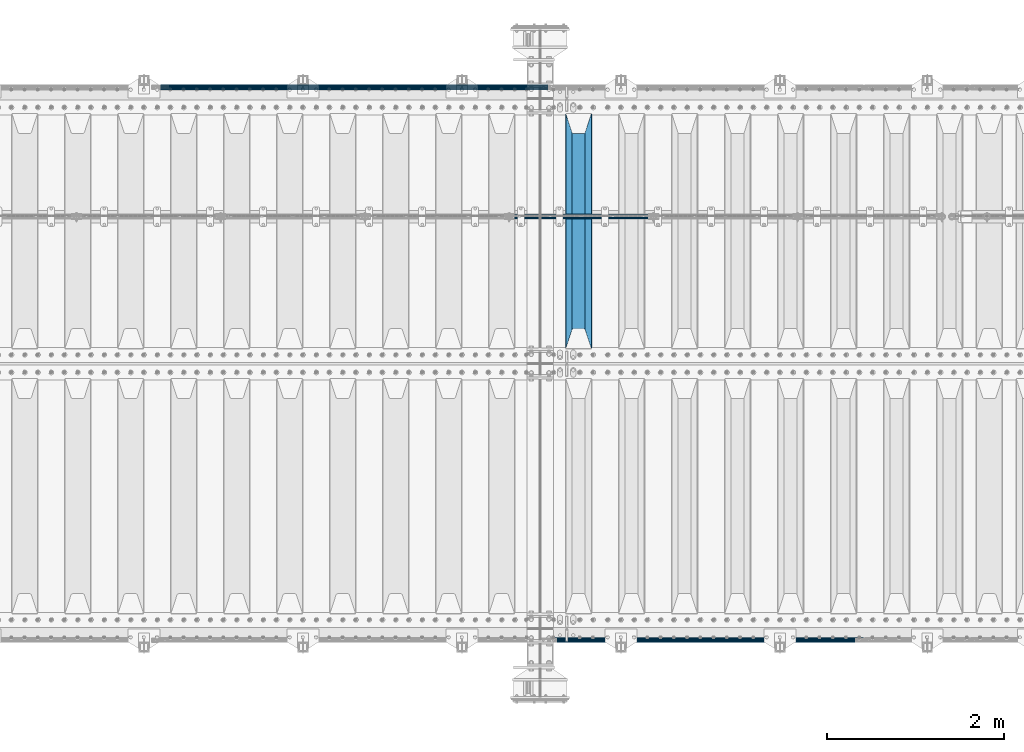
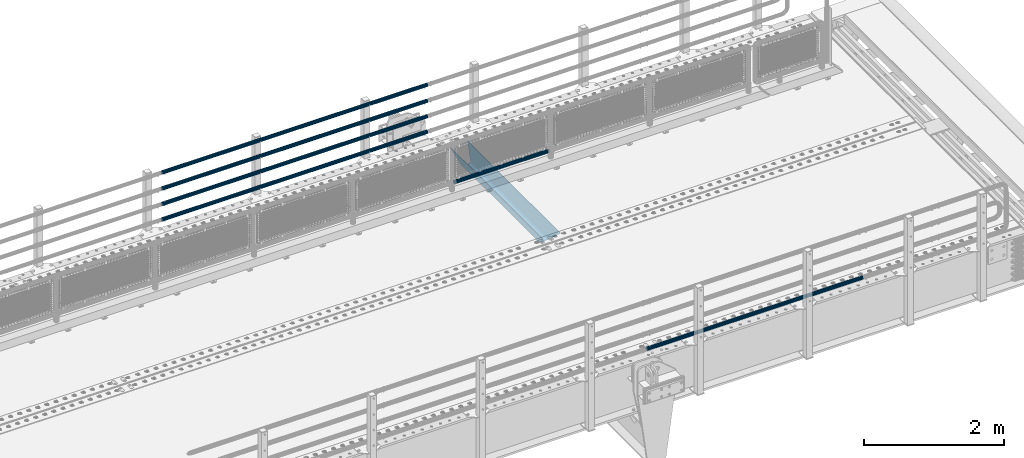
# One storey, part 127 of 242: 7 beams.
"""IFC2X3 building model written with IfcOpenShell, lengths in millimetres."""

from ifc_helpers import new_model, si_unit, frame, origin_with_axes, place, context, subcontext, project, spatial, faceted_brep, material, type_object, element, save


model = new_model("IFC2X3")

# Units and contexts
model_context = context("Model", 3, precision=1e-05, world=origin_with_axes())
body_context = subcontext(model_context, "Body", "Model", "MODEL_VIEW")
ifc_project = project(units=[si_unit("LENGTHUNIT", "METRE", prefix="MILLI"), si_unit("AREAUNIT", "SQUARE_METRE"), si_unit("VOLUMEUNIT", "CUBIC_METRE"), si_unit("MASSUNIT", "GRAM", prefix="KILO"), si_unit("TIMEUNIT", "SECOND"), si_unit("PLANEANGLEUNIT", "RADIAN"), si_unit("SOLIDANGLEUNIT", "STERADIAN"), si_unit("THERMODYNAMICTEMPERATUREUNIT", "DEGREE_CELSIUS"), si_unit("LUMINOUSINTENSITYUNIT", "LUMEN")], contexts=[model_context])

# Site, building, storey
site_placement = place(None, origin_with_axes())
site = spatial("IfcSite", under=ifc_project, at=site_placement, CompositionType="ELEMENT")
building_placement = place(site_placement, origin_with_axes())
building = spatial("IfcBuilding", under=site, at=building_placement, Name="Standard", CompositionType="ELEMENT")
storey_placement = place(building_placement, origin_with_axes())
storey = spatial("IfcBuildingStorey", under=building, at=storey_placement, Name="Undefined", CompositionType="ELEMENT", Elevation=0.0)

# Beams
ifc_material_1 = material()
beam_type_1 = type_object("IfcBeamType", PredefinedType="NOTDEFINED")
beam_1_placement = place(storey_placement, frame((-28730.15, -19335.5, 298.170000000001), z_axis=(0.0, 0.0, 1.0), x_axis=(1.0, 0.0, 0.0)))
element("IfcBeam", 1, at=beam_1_placement, inside=storey, type_object=beam_type_1, material=ifc_material_1, context=body_context, shape_type="Brep", body=[
    faceted_brep([(0.0, -25.3499999999985, 0.0), (0.0, -23.4203461491597, 9.70102501045403), (1563.0, -23.4203461491597, 9.70102501045506), (1563.0, -25.3499999999985, 0.0), (0.0, -17.9251569030785, 17.9251569030785), (1563.0, -17.9251569030785, 17.925156903079), (0.0, -9.70102501045403, 23.4203461491597), (1563.0, -9.70102501045403, 23.4203461491611), (0.0, 0.0, 25.3499999999985), (1563.0, 0.0, 25.35), (0.0, 9.70102501045403, 23.4203461491597), (1563.0, 9.70102501045403, 23.4203461491611), (0.0, 17.9251569030785, 17.9251569030785), (1563.0, 17.9251569030785, 17.925156903079), (0.0, 23.4203461491597, 9.70102501045403), (1563.0, 23.4203461491597, 9.70102501045506), (0.0, 25.3499999999985, 0.0), (1563.0, 25.3499999999985, 0.0), (0.0, 23.4203461491597, -9.70102501045403), (1563.0, 23.4203461491597, -9.70102501045506), (0.0, 17.9251569030785, -17.9251569030785), (1563.0, 17.9251569030785, -17.925156903079), (0.0, 9.70102501045403, -23.4203461491597), (1563.0, 9.70102501045403, -23.4203461491611), (0.0, 0.0, -25.3499999999985), (1563.0, 0.0, -25.35), (0.0, -9.70102501045403, -23.4203461491597), (1563.0, -9.70102501045403, -23.4203461491611), (0.0, -17.9251569030785, -17.9251569030785), (1563.0, -17.9251569030785, -17.925156903079), (0.0, -23.4203461491597, -9.70102501045403), (1563.0, -23.4203461491597, -9.70102501045506), (0.0, -30.1500000000015, 0.0), (0.0, -27.8549679052157, -11.5379054858058), (1563.0, -27.8549679052157, -11.5379054858075), (1563.0, -30.1500000000015, 0.0), (0.0, -21.3192694527752, -21.3192694527752), (1563.0, -21.3192694527752, -21.3192694527744), (0.0, -11.5379054858058, -27.8549679052157), (1563.0, -11.5379054858058, -27.8549679052153), (0.0, 0.0, -30.1500000000015), (1563.0, 0.0, -30.15), (0.0, 11.5379054858058, -27.8549679052157), (1563.0, 11.5379054858058, -27.8549679052153), (0.0, 21.3192694527752, -21.3192694527752), (1563.0, 21.3192694527752, -21.3192694527744), (0.0, 27.8549679052157, -11.5379054858058), (1563.0, 27.8549679052157, -11.5379054858074), (0.0, 30.1500000000015, 0.0), (1563.0, 30.1500000000015, 0.0), (0.0, 27.8549679052157, 11.5379054858058), (1563.0, 27.8549679052157, 11.5379054858074), (0.0, 21.3192694527752, 21.3192694527752), (1563.0, 21.3192694527752, 21.3192694527744), (0.0, 11.5379054858058, 27.8549679052157), (1563.0, 11.5379054858058, 27.8549679052153), (0.0, 0.0, 30.1500000000015), (1563.0, 0.0, 30.15), (0.0, -11.5379054858058, 27.8549679052157), (1563.0, -11.5379054858058, 27.8549679052153), (0.0, -21.3192694527752, 21.3192694527752), (1563.0, -21.3192694527752, 21.3192694527744), (0.0, -27.8549679052157, 11.5379054858058), (1563.0, -27.8549679052157, 11.5379054858074)], [[[0, 1, 2, 3]], [[1, 4, 5, 2]], [[4, 6, 7, 5]], [[6, 8, 9, 7]], [[8, 10, 11, 9]], [[10, 12, 13, 11]], [[12, 14, 15, 13]], [[14, 16, 17, 15]], [[16, 18, 19, 17]], [[18, 20, 21, 19]], [[20, 22, 23, 21]], [[22, 24, 25, 23]], [[24, 26, 27, 25]], [[26, 28, 29, 27]], [[28, 30, 31, 29]], [[30, 0, 3, 31]], [[32, 33, 34, 35]], [[33, 36, 37, 34]], [[36, 38, 39, 37]], [[38, 40, 41, 39]], [[40, 42, 43, 41]], [[42, 44, 45, 43]], [[44, 46, 47, 45]], [[46, 48, 49, 47]], [[48, 50, 51, 49]], [[50, 52, 53, 51]], [[52, 54, 55, 53]], [[54, 56, 57, 55]], [[56, 58, 59, 57]], [[58, 60, 61, 59]], [[60, 62, 63, 61]], [[62, 32, 35, 63]], [[37, 39, 41, 43, 45, 47, 49, 51, 53, 55, 57, 59, 61, 63, 35, 34], [5, 7, 9, 11, 13, 15, 17, 19, 21, 23, 25, 27, 29, 31, 3, 2]], [[62, 60, 58, 56, 54, 52, 50, 48, 46, 44, 42, 40, 38, 36, 33, 32], [30, 28, 26, 24, 22, 20, 18, 16, 14, 12, 10, 8, 6, 4, 1, 0]]]),
])
beam_type_2 = type_object("IfcBeamType", PredefinedType="NOTDEFINED")
beam_2_placement = place(storey_placement, frame((-28328.0000000001, -17870.1499999998, 149.849999999726), z_axis=(0.0, 0.0, -1.0), x_axis=(-1.0, 0.0, 0.0)))
element("IfcBeam", 2, at=beam_2_placement, inside=storey, type_object=beam_type_2, material=ifc_material_1, context=body_context, shape_type="Brep", body=[
    faceted_brep([(0.0, -26.5499999999993, 0.0), (0.0, -24.5290015881765, 10.1602451292931), (4384.0, -24.5290015881765, 10.1602451292931), (4384.0, -26.5499999999993, 0.0), (0.0, -18.7736850405017, 18.7736850405028), (4384.0, -18.7736850405017, 18.7736850405028), (0.0, -10.1602451292929, 24.5290015881747), (4384.0, -10.1602451292929, 24.5290015881747), (0.0, 0.0, 26.55), (4384.0, 0.0, 26.55), (0.0, 10.1602451292929, 24.5290015881747), (4384.0, 10.1602451292929, 24.5290015881747), (0.0, 18.7736850405017, 18.7736850405028), (4384.0, 18.7736850405017, 18.7736850405028), (0.0, 24.5290015881765, 10.1602451292931), (4384.0, 24.5290015881765, 10.1602451292931), (0.0, 26.5499999999993, 0.0), (4384.0, 26.5499999999993, 0.0), (0.0, 24.5290015881765, -10.1602451292931), (4384.0, 24.5290015881765, -10.1602451292931), (0.0, 18.7736850405017, -18.7736850405028), (4384.0, 18.7736850405017, -18.7736850405028), (0.0, 10.1602451292929, -24.5290015881747), (4384.0, 10.1602451292929, -24.5290015881747), (0.0, 0.0, -26.55), (4384.0, 0.0, -26.55), (0.0, -10.1602451292929, -24.5290015881747), (4384.0, -10.1602451292929, -24.5290015881747), (0.0, -18.7736850405017, -18.7736850405028), (4384.0, -18.7736850405017, -18.7736850405028), (0.0, -24.5290015881765, -10.1602451292931), (4384.0, -24.5290015881765, -10.1602451292931), (0.0, -30.1500000000015, 0.0), (0.0, -27.8549679052157, -11.5379054858058), (4384.0, -27.8549679052157, -11.5379054858075), (4384.0, -30.1500000000015, 0.0), (0.0, -21.3192694527752, -21.3192694527752), (4384.0, -21.3192694527752, -21.3192694527744), (0.0, -11.5379054858058, -27.8549679052157), (4384.0, -11.5379054858058, -27.8549679052153), (0.0, 0.0, -30.1500000000015), (4384.0, 0.0, -30.15), (0.0, 11.5379054858058, -27.8549679052157), (4384.0, 11.5379054858058, -27.8549679052153), (0.0, 21.3192694527752, -21.3192694527752), (4384.0, 21.3192694527752, -21.3192694527744), (0.0, 27.8549679052157, -11.5379054858058), (4384.0, 27.8549679052157, -11.5379054858074), (0.0, 30.1500000000015, 0.0), (4384.0, 30.1500000000015, 0.0), (0.0, 27.8549679052157, 11.5379054858058), (4384.0, 27.8549679052157, 11.5379054858075), (0.0, 21.3192694527752, 21.3192694527752), (4384.0, 21.3192694527752, 21.3192694527744), (0.0, 11.5379054858058, 27.8549679052157), (4384.0, 11.5379054858058, 27.8549679052153), (0.0, 0.0, 30.1500000000015), (4384.0, 0.0, 30.15), (0.0, -11.5379054858058, 27.8549679052157), (4384.0, -11.5379054858058, 27.8549679052153), (0.0, -21.3192694527752, 21.3192694527752), (4384.0, -21.3192694527752, 21.3192694527744), (0.0, -27.8549679052157, 11.5379054858058), (4384.0, -27.8549679052157, 11.5379054858075)], [[[0, 1, 2, 3]], [[1, 4, 5, 2]], [[4, 6, 7, 5]], [[6, 8, 9, 7]], [[8, 10, 11, 9]], [[10, 12, 13, 11]], [[12, 14, 15, 13]], [[14, 16, 17, 15]], [[16, 18, 19, 17]], [[18, 20, 21, 19]], [[20, 22, 23, 21]], [[22, 24, 25, 23]], [[24, 26, 27, 25]], [[26, 28, 29, 27]], [[28, 30, 31, 29]], [[30, 0, 3, 31]], [[32, 33, 34, 35]], [[33, 36, 37, 34]], [[36, 38, 39, 37]], [[38, 40, 41, 39]], [[40, 42, 43, 41]], [[42, 44, 45, 43]], [[44, 46, 47, 45]], [[46, 48, 49, 47]], [[48, 50, 51, 49]], [[50, 52, 53, 51]], [[52, 54, 55, 53]], [[54, 56, 57, 55]], [[56, 58, 59, 57]], [[58, 60, 61, 59]], [[60, 62, 63, 61]], [[62, 32, 35, 63]], [[37, 39, 41, 43, 45, 47, 49, 51, 53, 55, 57, 59, 61, 63, 35, 34], [5, 7, 9, 11, 13, 15, 17, 19, 21, 23, 25, 27, 29, 31, 3, 2]], [[62, 60, 58, 56, 54, 52, 50, 48, 46, 44, 42, 40, 38, 36, 33, 32], [30, 28, 26, 24, 22, 20, 18, 16, 14, 12, 10, 8, 6, 4, 1, 0]]]),
])
beam_3_placement = place(storey_placement, frame((-28328.0000000001, -17870.1499999998, 420.149999999729), z_axis=(0.0, 0.0, -1.0), x_axis=(-1.0, 0.0, 0.0)))
element("IfcBeam", 3, at=beam_3_placement, inside=storey, type_object=beam_type_2, material=ifc_material_1, context=body_context, shape_type="Brep", body=[
    faceted_brep([(0.0, -26.5499999999993, 0.0), (0.0, -24.5290015881765, 10.1602451292931), (4384.0, -24.5290015881765, 10.1602451292931), (4384.0, -26.5499999999993, 0.0), (0.0, -18.7736850405017, 18.7736850405028), (4384.0, -18.7736850405017, 18.7736850405028), (0.0, -10.1602451292929, 24.5290015881747), (4384.0, -10.1602451292929, 24.5290015881747), (0.0, 0.0, 26.55), (4384.0, 0.0, 26.55), (0.0, 10.1602451292929, 24.5290015881747), (4384.0, 10.1602451292929, 24.5290015881747), (0.0, 18.7736850405017, 18.7736850405028), (4384.0, 18.7736850405017, 18.7736850405028), (0.0, 24.5290015881765, 10.1602451292931), (4384.0, 24.5290015881765, 10.1602451292931), (0.0, 26.5499999999993, 0.0), (4384.0, 26.5499999999993, 0.0), (0.0, 24.5290015881765, -10.1602451292931), (4384.0, 24.5290015881765, -10.1602451292931), (0.0, 18.7736850405017, -18.7736850405028), (4384.0, 18.7736850405017, -18.7736850405028), (0.0, 10.1602451292929, -24.5290015881747), (4384.0, 10.1602451292929, -24.5290015881747), (0.0, 0.0, -26.55), (4384.0, 0.0, -26.55), (0.0, -10.1602451292929, -24.5290015881747), (4384.0, -10.1602451292929, -24.5290015881747), (0.0, -18.7736850405017, -18.7736850405028), (4384.0, -18.7736850405017, -18.7736850405028), (0.0, -24.5290015881765, -10.1602451292931), (4384.0, -24.5290015881765, -10.1602451292931), (0.0, -30.1500000000015, 0.0), (0.0, -27.8549679052157, -11.5379054858058), (4384.0, -27.8549679052157, -11.5379054858075), (4384.0, -30.1500000000015, 0.0), (0.0, -21.3192694527752, -21.3192694527752), (4384.0, -21.3192694527752, -21.3192694527744), (0.0, -11.5379054858058, -27.8549679052157), (4384.0, -11.5379054858058, -27.8549679052153), (0.0, 0.0, -30.1500000000015), (4384.0, 0.0, -30.15), (0.0, 11.5379054858058, -27.8549679052157), (4384.0, 11.5379054858058, -27.8549679052153), (0.0, 21.3192694527752, -21.3192694527752), (4384.0, 21.3192694527752, -21.3192694527744), (0.0, 27.8549679052157, -11.5379054858058), (4384.0, 27.8549679052157, -11.5379054858074), (0.0, 30.1500000000015, 0.0), (4384.0, 30.1500000000015, 0.0), (0.0, 27.8549679052157, 11.5379054858058), (4384.0, 27.8549679052157, 11.5379054858075), (0.0, 21.3192694527752, 21.3192694527752), (4384.0, 21.3192694527752, 21.3192694527744), (0.0, 11.5379054858058, 27.8549679052157), (4384.0, 11.5379054858058, 27.8549679052153), (0.0, 0.0, 30.1500000000015), (4384.0, 0.0, 30.15), (0.0, -11.5379054858058, 27.8549679052157), (4384.0, -11.5379054858058, 27.8549679052153), (0.0, -21.3192694527752, 21.3192694527752), (4384.0, -21.3192694527752, 21.3192694527744), (0.0, -27.8549679052157, 11.5379054858058), (4384.0, -27.8549679052157, 11.5379054858075)], [[[0, 1, 2, 3]], [[1, 4, 5, 2]], [[4, 6, 7, 5]], [[6, 8, 9, 7]], [[8, 10, 11, 9]], [[10, 12, 13, 11]], [[12, 14, 15, 13]], [[14, 16, 17, 15]], [[16, 18, 19, 17]], [[18, 20, 21, 19]], [[20, 22, 23, 21]], [[22, 24, 25, 23]], [[24, 26, 27, 25]], [[26, 28, 29, 27]], [[28, 30, 31, 29]], [[30, 0, 3, 31]], [[32, 33, 34, 35]], [[33, 36, 37, 34]], [[36, 38, 39, 37]], [[38, 40, 41, 39]], [[40, 42, 43, 41]], [[42, 44, 45, 43]], [[44, 46, 47, 45]], [[46, 48, 49, 47]], [[48, 50, 51, 49]], [[50, 52, 53, 51]], [[52, 54, 55, 53]], [[54, 56, 57, 55]], [[56, 58, 59, 57]], [[58, 60, 61, 59]], [[60, 62, 63, 61]], [[62, 32, 35, 63]], [[37, 39, 41, 43, 45, 47, 49, 51, 53, 55, 57, 59, 61, 63, 35, 34], [5, 7, 9, 11, 13, 15, 17, 19, 21, 23, 25, 27, 29, 31, 3, 2]], [[62, 60, 58, 56, 54, 52, 50, 48, 46, 44, 42, 40, 38, 36, 33, 32], [30, 28, 26, 24, 22, 20, 18, 16, 14, 12, 10, 8, 6, 4, 1, 0]]]),
])
beam_4_placement = place(storey_placement, frame((-28328.0000000001, -17870.1499999998, 969.849999999726), z_axis=(0.0, 0.0, -1.0), x_axis=(-1.0, 0.0, 0.0)))
element("IfcBeam", 4, at=beam_4_placement, inside=storey, type_object=beam_type_2, material=ifc_material_1, context=body_context, shape_type="Brep", body=[
    faceted_brep([(0.0, -26.5499999999993, 0.0), (0.0, -24.5290015881765, 10.1602451292931), (4384.0, -24.5290015881765, 10.1602451292931), (4384.0, -26.5499999999993, 0.0), (0.0, -18.7736850405017, 18.7736850405028), (4384.0, -18.7736850405017, 18.7736850405028), (0.0, -10.1602451292929, 24.5290015881747), (4384.0, -10.1602451292929, 24.5290015881747), (0.0, 0.0, 26.55), (4384.0, 0.0, 26.55), (0.0, 10.1602451292929, 24.5290015881747), (4384.0, 10.1602451292929, 24.5290015881747), (0.0, 18.7736850405017, 18.7736850405028), (4384.0, 18.7736850405017, 18.7736850405028), (0.0, 24.5290015881765, 10.1602451292931), (4384.0, 24.5290015881765, 10.1602451292931), (0.0, 26.5499999999993, 0.0), (4384.0, 26.5499999999993, 0.0), (0.0, 24.5290015881765, -10.1602451292931), (4384.0, 24.5290015881765, -10.1602451292931), (0.0, 18.7736850405017, -18.7736850405028), (4384.0, 18.7736850405017, -18.7736850405028), (0.0, 10.1602451292929, -24.5290015881747), (4384.0, 10.1602451292929, -24.5290015881747), (0.0, 0.0, -26.55), (4384.0, 0.0, -26.55), (0.0, -10.1602451292929, -24.5290015881747), (4384.0, -10.1602451292929, -24.5290015881747), (0.0, -18.7736850405017, -18.7736850405028), (4384.0, -18.7736850405017, -18.7736850405028), (0.0, -24.5290015881765, -10.1602451292931), (4384.0, -24.5290015881765, -10.1602451292931), (0.0, -30.1500000000015, 0.0), (0.0, -27.8549679052157, -11.5379054858058), (4384.0, -27.8549679052157, -11.5379054858075), (4384.0, -30.1500000000015, 0.0), (0.0, -21.3192694527752, -21.3192694527752), (4384.0, -21.3192694527752, -21.3192694527744), (0.0, -11.5379054858058, -27.8549679052157), (4384.0, -11.5379054858058, -27.8549679052153), (0.0, 0.0, -30.1500000000015), (4384.0, 0.0, -30.15), (0.0, 11.5379054858058, -27.8549679052157), (4384.0, 11.5379054858058, -27.8549679052153), (0.0, 21.3192694527752, -21.3192694527752), (4384.0, 21.3192694527752, -21.3192694527744), (0.0, 27.8549679052157, -11.5379054858058), (4384.0, 27.8549679052157, -11.5379054858074), (0.0, 30.1500000000015, 0.0), (4384.0, 30.1500000000015, 0.0), (0.0, 27.8549679052157, 11.5379054858058), (4384.0, 27.8549679052157, 11.5379054858075), (0.0, 21.3192694527752, 21.3192694527752), (4384.0, 21.3192694527752, 21.3192694527744), (0.0, 11.5379054858058, 27.8549679052157), (4384.0, 11.5379054858058, 27.8549679052153), (0.0, 0.0, 30.1500000000015), (4384.0, 0.0, 30.15), (0.0, -11.5379054858058, 27.8549679052157), (4384.0, -11.5379054858058, 27.8549679052153), (0.0, -21.3192694527752, 21.3192694527752), (4384.0, -21.3192694527752, 21.3192694527744), (0.0, -27.8549679052157, 11.5379054858058), (4384.0, -27.8549679052157, 11.5379054858075)], [[[0, 1, 2, 3]], [[1, 4, 5, 2]], [[4, 6, 7, 5]], [[6, 8, 9, 7]], [[8, 10, 11, 9]], [[10, 12, 13, 11]], [[12, 14, 15, 13]], [[14, 16, 17, 15]], [[16, 18, 19, 17]], [[18, 20, 21, 19]], [[20, 22, 23, 21]], [[22, 24, 25, 23]], [[24, 26, 27, 25]], [[26, 28, 29, 27]], [[28, 30, 31, 29]], [[30, 0, 3, 31]], [[32, 33, 34, 35]], [[33, 36, 37, 34]], [[36, 38, 39, 37]], [[38, 40, 41, 39]], [[40, 42, 43, 41]], [[42, 44, 45, 43]], [[44, 46, 47, 45]], [[46, 48, 49, 47]], [[48, 50, 51, 49]], [[50, 52, 53, 51]], [[52, 54, 55, 53]], [[54, 56, 57, 55]], [[56, 58, 59, 57]], [[58, 60, 61, 59]], [[60, 62, 63, 61]], [[62, 32, 35, 63]], [[37, 39, 41, 43, 45, 47, 49, 51, 53, 55, 57, 59, 61, 63, 35, 34], [5, 7, 9, 11, 13, 15, 17, 19, 21, 23, 25, 27, 29, 31, 3, 2]], [[62, 60, 58, 56, 54, 52, 50, 48, 46, 44, 42, 40, 38, 36, 33, 32], [30, 28, 26, 24, 22, 20, 18, 16, 14, 12, 10, 8, 6, 4, 1, 0]]]),
])
beam_5_placement = place(storey_placement, frame((-28328.0000000001, -17870.1499999998, 689.849999999726), z_axis=(0.0, 0.0, -1.0), x_axis=(-1.0, 0.0, 0.0)))
element("IfcBeam", 5, at=beam_5_placement, inside=storey, type_object=beam_type_2, material=ifc_material_1, context=body_context, shape_type="Brep", body=[
    faceted_brep([(0.0, -26.5499999999993, 0.0), (0.0, -24.5290015881765, 10.1602451292931), (4384.0, -24.5290015881765, 10.1602451292931), (4384.0, -26.5499999999993, 0.0), (0.0, -18.7736850405017, 18.7736850405028), (4384.0, -18.7736850405017, 18.7736850405028), (0.0, -10.1602451292929, 24.5290015881747), (4384.0, -10.1602451292929, 24.5290015881747), (0.0, 0.0, 26.55), (4384.0, 0.0, 26.55), (0.0, 10.1602451292929, 24.5290015881747), (4384.0, 10.1602451292929, 24.5290015881747), (0.0, 18.7736850405017, 18.7736850405028), (4384.0, 18.7736850405017, 18.7736850405028), (0.0, 24.5290015881765, 10.1602451292931), (4384.0, 24.5290015881765, 10.1602451292931), (0.0, 26.5499999999993, 0.0), (4384.0, 26.5499999999993, 0.0), (0.0, 24.5290015881765, -10.1602451292931), (4384.0, 24.5290015881765, -10.1602451292931), (0.0, 18.7736850405017, -18.7736850405028), (4384.0, 18.7736850405017, -18.7736850405028), (0.0, 10.1602451292929, -24.5290015881747), (4384.0, 10.1602451292929, -24.5290015881747), (0.0, 0.0, -26.55), (4384.0, 0.0, -26.55), (0.0, -10.1602451292929, -24.5290015881747), (4384.0, -10.1602451292929, -24.5290015881747), (0.0, -18.7736850405017, -18.7736850405028), (4384.0, -18.7736850405017, -18.7736850405028), (0.0, -24.5290015881765, -10.1602451292931), (4384.0, -24.5290015881765, -10.1602451292931), (0.0, -30.1500000000015, 0.0), (0.0, -27.8549679052157, -11.5379054858058), (4384.0, -27.8549679052157, -11.5379054858075), (4384.0, -30.1500000000015, 0.0), (0.0, -21.3192694527752, -21.3192694527752), (4384.0, -21.3192694527752, -21.3192694527744), (0.0, -11.5379054858058, -27.8549679052157), (4384.0, -11.5379054858058, -27.8549679052153), (0.0, 0.0, -30.1500000000015), (4384.0, 0.0, -30.15), (0.0, 11.5379054858058, -27.8549679052157), (4384.0, 11.5379054858058, -27.8549679052153), (0.0, 21.3192694527752, -21.3192694527752), (4384.0, 21.3192694527752, -21.3192694527744), (0.0, 27.8549679052157, -11.5379054858058), (4384.0, 27.8549679052157, -11.5379054858074), (0.0, 30.1500000000015, 0.0), (4384.0, 30.1500000000015, 0.0), (0.0, 27.8549679052157, 11.5379054858058), (4384.0, 27.8549679052157, 11.5379054858075), (0.0, 21.3192694527752, 21.3192694527752), (4384.0, 21.3192694527752, 21.3192694527744), (0.0, 11.5379054858058, 27.8549679052157), (4384.0, 11.5379054858058, 27.8549679052153), (0.0, 0.0, 30.1500000000015), (4384.0, 0.0, 30.15), (0.0, -11.5379054858058, 27.8549679052157), (4384.0, -11.5379054858058, 27.8549679052153), (0.0, -21.3192694527752, 21.3192694527752), (4384.0, -21.3192694527752, 21.3192694527744), (0.0, -27.8549679052157, 11.5379054858058), (4384.0, -27.8549679052157, 11.5379054858075)], [[[0, 1, 2, 3]], [[1, 4, 5, 2]], [[4, 6, 7, 5]], [[6, 8, 9, 7]], [[8, 10, 11, 9]], [[10, 12, 13, 11]], [[12, 14, 15, 13]], [[14, 16, 17, 15]], [[16, 18, 19, 17]], [[18, 20, 21, 19]], [[20, 22, 23, 21]], [[22, 24, 25, 23]], [[24, 26, 27, 25]], [[26, 28, 29, 27]], [[28, 30, 31, 29]], [[30, 0, 3, 31]], [[32, 33, 34, 35]], [[33, 36, 37, 34]], [[36, 38, 39, 37]], [[38, 40, 41, 39]], [[40, 42, 43, 41]], [[42, 44, 45, 43]], [[44, 46, 47, 45]], [[46, 48, 49, 47]], [[48, 50, 51, 49]], [[50, 52, 53, 51]], [[52, 54, 55, 53]], [[54, 56, 57, 55]], [[56, 58, 59, 57]], [[58, 60, 61, 59]], [[60, 62, 63, 61]], [[62, 32, 35, 63]], [[37, 39, 41, 43, 45, 47, 49, 51, 53, 55, 57, 59, 61, 63, 35, 34], [5, 7, 9, 11, 13, 15, 17, 19, 21, 23, 25, 27, 29, 31, 3, 2]], [[62, 60, 58, 56, 54, 52, 50, 48, 46, 44, 42, 40, 38, 36, 33, 32], [30, 28, 26, 24, 22, 20, 18, 16, 14, 12, 10, 8, 6, 4, 1, 0]]]),
])
beam_6_placement = place(storey_placement, frame((-24755.0000000001, -24129.8499999998, 149.849999999726), z_axis=(0.0, 0.0, -1.0), x_axis=(-1.0, 0.0, 0.0)))
element("IfcBeam", 6, at=beam_6_placement, inside=storey, type_object=beam_type_2, material=ifc_material_1, context=body_context, shape_type="Brep", body=[
    faceted_brep([(0.0, -26.5499999999993, 0.0), (0.0, -24.5290015881765, 10.1602451292931), (3563.0, -24.5290015881765, 10.1602451292931), (3563.0, -26.5499999999993, 0.0), (0.0, -18.7736850405017, 18.7736850405028), (3563.0, -18.7736850405017, 18.7736850405028), (0.0, -10.1602451292929, 24.5290015881747), (3563.0, -10.1602451292929, 24.5290015881747), (0.0, 0.0, 26.55), (3563.0, 0.0, 26.55), (0.0, 10.1602451292929, 24.5290015881747), (3563.0, 10.1602451292929, 24.5290015881747), (0.0, 18.7736850405017, 18.7736850405028), (3563.0, 18.7736850405017, 18.7736850405028), (0.0, 24.5290015881765, 10.1602451292931), (3563.0, 24.5290015881765, 10.1602451292931), (0.0, 26.5499999999993, 0.0), (3563.0, 26.5499999999993, 0.0), (0.0, 24.5290015881765, -10.1602451292931), (3563.0, 24.5290015881765, -10.1602451292931), (0.0, 18.7736850405017, -18.7736850405028), (3563.0, 18.7736850405017, -18.7736850405028), (0.0, 10.1602451292929, -24.5290015881747), (3563.0, 10.1602451292929, -24.5290015881747), (0.0, 0.0, -26.55), (3563.0, 0.0, -26.55), (0.0, -10.1602451292929, -24.5290015881747), (3563.0, -10.1602451292929, -24.5290015881747), (0.0, -18.7736850405017, -18.7736850405028), (3563.0, -18.7736850405017, -18.7736850405028), (0.0, -24.5290015881765, -10.1602451292931), (3563.0, -24.5290015881765, -10.1602451292931), (0.0, -30.1500000000015, 0.0), (0.0, -27.8549679052157, -11.5379054858058), (3563.0, -27.8549679052157, -11.5379054858075), (3563.0, -30.1500000000015, 0.0), (0.0, -21.3192694527752, -21.3192694527752), (3563.0, -21.3192694527752, -21.3192694527744), (0.0, -11.5379054858058, -27.8549679052157), (3563.0, -11.5379054858058, -27.8549679052153), (0.0, 0.0, -30.1500000000015), (3563.0, 0.0, -30.15), (0.0, 11.5379054858058, -27.8549679052157), (3563.0, 11.5379054858058, -27.8549679052153), (0.0, 21.3192694527752, -21.3192694527752), (3563.0, 21.3192694527752, -21.3192694527744), (0.0, 27.8549679052157, -11.5379054858058), (3563.0, 27.8549679052157, -11.5379054858074), (0.0, 30.1500000000015, 0.0), (3563.0, 30.1500000000015, 0.0), (0.0, 27.8549679052157, 11.5379054858058), (3563.0, 27.8549679052157, 11.5379054858075), (0.0, 21.3192694527752, 21.3192694527752), (3563.0, 21.3192694527752, 21.3192694527744), (0.0, 11.5379054858058, 27.8549679052157), (3563.0, 11.5379054858058, 27.8549679052153), (0.0, 0.0, 30.1500000000015), (3563.0, 0.0, 30.15), (0.0, -11.5379054858058, 27.8549679052157), (3563.0, -11.5379054858058, 27.8549679052153), (0.0, -21.3192694527752, 21.3192694527752), (3563.0, -21.3192694527752, 21.3192694527744), (0.0, -27.8549679052157, 11.5379054858058), (3563.0, -27.8549679052157, 11.5379054858075)], [[[0, 1, 2, 3]], [[1, 4, 5, 2]], [[4, 6, 7, 5]], [[6, 8, 9, 7]], [[8, 10, 11, 9]], [[10, 12, 13, 11]], [[12, 14, 15, 13]], [[14, 16, 17, 15]], [[16, 18, 19, 17]], [[18, 20, 21, 19]], [[20, 22, 23, 21]], [[22, 24, 25, 23]], [[24, 26, 27, 25]], [[26, 28, 29, 27]], [[28, 30, 31, 29]], [[30, 0, 3, 31]], [[32, 33, 34, 35]], [[33, 36, 37, 34]], [[36, 38, 39, 37]], [[38, 40, 41, 39]], [[40, 42, 43, 41]], [[42, 44, 45, 43]], [[44, 46, 47, 45]], [[46, 48, 49, 47]], [[48, 50, 51, 49]], [[50, 52, 53, 51]], [[52, 54, 55, 53]], [[54, 56, 57, 55]], [[56, 58, 59, 57]], [[58, 60, 61, 59]], [[60, 62, 63, 61]], [[62, 32, 35, 63]], [[37, 39, 41, 43, 45, 47, 49, 51, 53, 55, 57, 59, 61, 63, 35, 34], [5, 7, 9, 11, 13, 15, 17, 19, 21, 23, 25, 27, 29, 31, 3, 2]], [[62, 60, 58, 56, 54, 52, 50, 48, 46, 44, 42, 40, 38, 36, 33, 32], [30, 28, 26, 24, 22, 20, 18, 16, 14, 12, 10, 8, 6, 4, 1, 0]]]),
])
ifc_material_2 = material(Name="STEEL/S355N")
beam_type_3 = type_object("IfcBeamType", PredefinedType="NOTDEFINED")
beam_7_placement = place(storey_placement, frame((-27980.0, -20825.0, -115.0), z_axis=(0.0, 0.0, 1.0), x_axis=(0.0, 1.0, 0.0)))
element("IfcBeam", 7, at=beam_7_placement, inside=storey, type_object=beam_type_3, material=ifc_material_2, context=body_context, shape_type="Brep", body=[
    faceted_brep([(0.0, 150.0, 115.0), (0.0, 143.689999999999, 115.0), (2650.00000000297, 143.689999999999, 115.0), (2650.00000000297, 150.0, 115.0), (2650.00000000297, 142.059565218402, 110.000000003099), (2650.00000000297, 148.369565218403, 110.000000003099), (2441.90079219209, -80.1103600731112, -98.0992078077845), (2437.7588105432, -77.5672621345584, -102.241189456673), (2434.06523489747, -74.4080125315522, -105.934765102404), (2430.91086095089, -70.710272125576, -109.089139048974), (2428.37322971128, -66.5649389910068, -111.626770288588), (2426.51472138055, -62.0739139532889, -113.485278619323), (2425.38102192092, -57.3475956567672, -114.618978078955), (2424.99999999987, -52.5021667386536, -115.0), (2424.99999999987, 52.5021667386536, -115.0), (2425.38102192092, 57.3475956567672, -114.618978078955), (2426.51472138055, 62.0739139532889, -113.485278619323), (2428.37322971128, 66.5649389910068, -111.626770288588), (2430.91086095089, 70.710272125576, -109.089139048974), (2434.06523489747, 74.4080125315522, -105.934765102404), (2437.7588105432, 77.5672621345584, -102.241189456673), (2441.90079219209, 80.1103600731112, -98.0992078077846), (2446.38936140511, 81.9747917625791, -93.6106385947584), (2448.2494850041, 76.2713538057251, -91.7505149957729), (2444.62967112262, 74.76777986261, -95.3703288772456), (2441.28936334126, 72.7168944282894, -98.710636658607), (2438.31067330438, 70.1691124903846, -101.689326695487), (2435.76682334747, 67.1870637758839, -104.233176652398), (2433.72034654133, 63.8440531834895, -106.279653458539), (2432.22154950042, 60.222258798236, -107.778450499454), (2431.30727574265, 56.4107117849089, -108.692724257221), (2430.99999999987, 52.5031078186876, -109.0), (2430.99999999987, -52.5031078186876, -109.0), (2431.30727574265, -56.4107117849089, -108.692724257221), (2432.22154950042, -60.222258798236, -107.778450499454), (2433.72034654133, -63.8440531834895, -106.279653458539), (2435.76682334747, -67.1870637758839, -104.233176652398), (2438.31067330438, -70.1691124903846, -101.689326695487), (2441.28936334126, -72.7168944282894, -98.7106366586071), (2444.62967112262, -74.76777986261, -95.3703288772457), (2448.2494850041, -76.2713538057251, -91.7505149957729), (2650.00000000297, -142.059565218402, 110.000000003099), (2650.00000000297, -148.369565218403, 110.000000003099), (2446.38936140511, -81.9747917625791, -93.6106385947584), (2650.00000000297, -143.689999999999, 115.0), (2650.00000000297, -150.0, 115.0), (0.0, -143.689999999999, 115.0), (0.0, -150.0, 115.0), (0.0, -148.369565218261, 110.000000002669), (203.610638597427, -81.9747917625791, -93.6106385947584), (208.099207810454, -80.1103600731112, -98.0992078077845), (212.241189459342, -77.5672621345584, -102.241189456673), (215.934765105074, -74.4080125315522, -105.934765102404), (219.089139051644, -70.710272125576, -109.089139048974), (221.626770291256, -66.5649389910068, -111.626770288588), (223.485278621993, -62.0739139532889, -113.485278619323), (224.618978081624, -57.3475956567672, -114.618978078955), (225.00000000267, -52.5021667386536, -115.0), (225.00000000267, 52.5021667386536, -115.0), (224.618978081624, 57.3475956567672, -114.618978078955), (223.485278621993, 62.0739139532889, -113.485278619323), (221.626770291256, 66.5649389910068, -111.626770288588), (219.089139051644, 70.710272125576, -109.089139048974), (215.934765105074, 74.4080125315522, -105.934765102404), (212.241189459342, 77.5672621345584, -102.241189456673), (208.099207810454, 80.1103600731112, -98.0992078077846), (203.610638597427, 81.9747917625791, -93.6106385947584), (0.0, 148.369565218261, 110.000000002669), (0.0, 142.05956521826, 110.000000002669), (201.750514998443, 76.2713538057251, -91.7505149957729), (205.370328879915, 74.76777986261, -95.3703288772456), (208.710636661275, 72.7168944282894, -98.710636658607), (211.689326698157, 70.1691124903846, -101.689326695487), (214.233176655067, 67.1870637758839, -104.233176652398), (216.279653461206, 63.8440531834895, -106.279653458539), (217.778450502123, 60.222258798236, -107.778450499454), (218.69272425989, 56.4107117849089, -108.692724257221), (219.00000000267, 52.5031078186876, -109.0), (219.00000000267, -52.5031078186876, -109.0), (218.69272425989, -56.4107117849089, -108.692724257221), (217.778450502123, -60.222258798236, -107.778450499454), (216.279653461206, -63.8440531834895, -106.279653458539), (214.233176655067, -67.1870637758839, -104.233176652398), (211.689326698157, -70.1691124903846, -101.689326695487), (208.710636661275, -72.7168944282894, -98.7106366586071), (205.370328879915, -74.76777986261, -95.3703288772457), (201.750514998443, -76.2713538057251, -91.7505149957729), (0.0, -142.05956521826, 110.000000002669)], [[[0, 1, 2, 3]], [[3, 2, 4, 5]], [[6, 7, 8, 9, 10, 11, 12, 13, 14, 15, 16, 17, 18, 19, 20, 21, 22, 5, 4, 23, 24, 25, 26, 27, 28, 29, 30, 31, 32, 33, 34, 35, 36, 37, 38, 39, 40, 41, 42, 43]], [[44, 45, 42, 41]], [[46, 47, 45, 44]], [[43, 42, 45, 47, 48, 49]], [[6, 43, 49, 50]], [[7, 6, 50, 51]], [[8, 7, 51, 52]], [[9, 8, 52, 53]], [[10, 9, 53, 54]], [[11, 10, 54, 55]], [[12, 11, 55, 56]], [[13, 12, 56, 57]], [[14, 13, 57, 58]], [[15, 14, 58, 59]], [[16, 15, 59, 60]], [[17, 16, 60, 61]], [[18, 17, 61, 62]], [[19, 18, 62, 63]], [[20, 19, 63, 64]], [[21, 20, 64, 65]], [[22, 21, 65, 66]], [[0, 3, 5, 22, 66, 67]], [[1, 0, 67, 68]], [[23, 4, 2, 1, 68, 69]], [[24, 23, 69, 70]], [[25, 24, 70, 71]], [[26, 25, 71, 72]], [[27, 26, 72, 73]], [[28, 27, 73, 74]], [[29, 28, 74, 75]], [[30, 29, 75, 76]], [[31, 30, 76, 77]], [[32, 31, 77, 78]], [[33, 32, 78, 79]], [[34, 33, 79, 80]], [[35, 34, 80, 81]], [[36, 35, 81, 82]], [[37, 36, 82, 83]], [[38, 37, 83, 84]], [[39, 38, 84, 85]], [[40, 39, 85, 86]], [[46, 44, 41, 40, 86, 87]], [[47, 46, 87, 48]], [[86, 85, 84, 83, 82, 81, 80, 79, 78, 77, 76, 75, 74, 73, 72, 71, 70, 69, 68, 67, 66, 65, 64, 63, 62, 61, 60, 59, 58, 57, 56, 55, 54, 53, 52, 51, 50, 49, 48, 87]]]),
])

save(model, "model.ifc")
